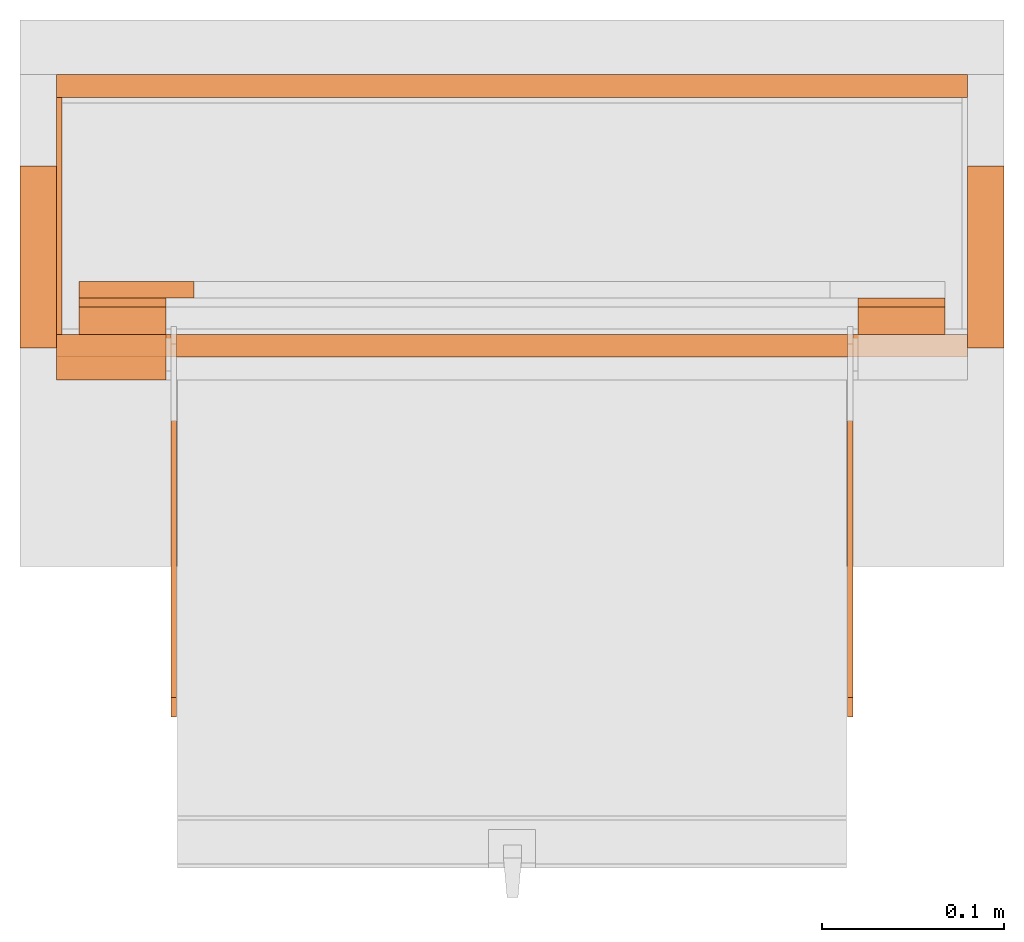
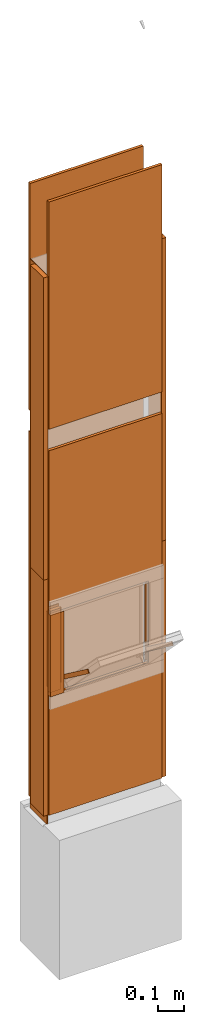
# One storey, part 1 of 3: 18 proxies, 1 opening.
"""IFC2X3 building model written with IfcOpenShell, lengths in metres."""

from ifc_helpers import new_model, entity, si_unit, converted_unit, derived_unit, money_unit, direction, frame, origin_with_axes, origin_2d_with_axis, place, context, subcontext, project, spatial, polyline, rectangle, outline, extrude, faceted_brep, source, transform, mapped, material, type_object, element, save


model = new_model("IFC2X3")

# Units and contexts
model_context = context("Model", 3, precision=1e-05, world=origin_with_axes(), true_north=direction((0.0, 1.0)))
plan_context = context("Plan", 3, precision=1e-05, world=origin_with_axes(), true_north=direction((0.0, 1.0)))
body_context = subcontext(model_context, "Body", "Model", "MODEL_VIEW")
ifc_project = project(units=[si_unit("LENGTHUNIT", "METRE"), si_unit("AREAUNIT", "SQUARE_METRE"), si_unit("VOLUMEUNIT", "CUBIC_METRE"), converted_unit("PLANEANGLEUNIT", "DEGREE", entity("IfcPlaneAngleMeasure", 0.0174532925199), si_unit("PLANEANGLEUNIT", "RADIAN"), dimensions=[0, 0, 0, 0, 0, 0, 0]), si_unit("SOLIDANGLEUNIT", "STERADIAN"), money_unit("CHF"), converted_unit("TIMEUNIT", "Year", entity("IfcTimeMeasure", 31556926.0), si_unit("TIMEUNIT", "SECOND"), dimensions=[0, 0, 1, 0, 0, 0, 0]), si_unit("MASSUNIT", "GRAM", prefix="KILO"), si_unit("THERMODYNAMICTEMPERATUREUNIT", "DEGREE_CELSIUS"), si_unit("LUMINOUSINTENSITYUNIT", "LUMEN"), si_unit("ENERGYUNIT", "JOULE", prefix="MEGA"), derived_unit("THERMALCONDUCTANCEUNIT", [(si_unit("POWERUNIT", "WATT"), 1), (si_unit("LENGTHUNIT", "METRE"), -1), (si_unit("THERMODYNAMICTEMPERATUREUNIT", "KELVIN"), -1)]), derived_unit("SPECIFICHEATCAPACITYUNIT", [(si_unit("ENERGYUNIT", "JOULE"), 1), (si_unit("MASSUNIT", "GRAM", prefix="KILO"), -1), (si_unit("THERMODYNAMICTEMPERATUREUNIT", "KELVIN"), -1)]), derived_unit("MASSDENSITYUNIT", [(si_unit("MASSUNIT", "GRAM", prefix="KILO"), 1), (si_unit("VOLUMEUNIT", "CUBIC_METRE"), -1)])], contexts=[model_context, plan_context])

# Site, building, storey
site_placement = place(None, origin_with_axes())
site = spatial("IfcSite", under=ifc_project, at=site_placement, CompositionType="ELEMENT")
building_placement = place(site_placement, origin_with_axes())
building = spatial("IfcBuilding", under=site, at=building_placement, CompositionType="ELEMENT")
storey_placement = place(building_placement, origin_with_axes())
storey = spatial("IfcBuildingStorey", under=building, at=storey_placement, Name="EG00", CompositionType="ELEMENT", Elevation=0.0)

# Proxies
ifc_material_1 = material(Name="Metall, Stahl")
building_element_proxy_type_1 = type_object("IfcBuildingElementProxyType", Name="Metall, Stahl 3", PredefinedType="NOTDEFINED")
proxy_1_placement = place(storey_placement, frame((9.11522436818, -3.75878861887, 0.0), z_axis=(0.0, 0.0, 1.0), x_axis=(0.0, -1.0, 0.0)))
element("IfcBuildingElementProxy", 1, at=proxy_1_placement, inside=storey, type_object=building_element_proxy_type_1, material=ifc_material_1, Name="Wand-005", context=body_context, shape_type="SweptSolid", body=[
    extrude(outline(polyline([(0.0, 0.0), (0.13, 0.0), (0.13, 0.003), (0.0, 0.003), (0.0, 0.0)])), origin_with_axes(), (0.0, 0.0, 1.0), 1.15),
])
proxy_2_placement = place(storey_placement, frame((9.11522436818, -3.75878861887, 1.15), z_axis=(0.0, 0.0, 1.0), x_axis=(0.0, -1.0, 0.0)))
element("IfcBuildingElementProxy", 2, at=proxy_2_placement, inside=storey, type_object=building_element_proxy_type_1, material=ifc_material_1, Name="Wand-005", context=body_context, shape_type="SweptSolid", body=[
    extrude(outline(polyline([(0.0, 0.0), (0.13, 0.0), (0.13, 0.003), (0.0, 0.003), (0.0, 0.0)])), origin_with_axes(), (0.0, 0.0, 1.0), 1.41),
])
ifc_material_2 = material(Name="Holz")
building_element_proxy_type_2 = type_object("IfcBuildingElementProxyType", Name="Holz 15", PredefinedType="NOTDEFINED")
for number, where, z_axis, x_axis, name in (
    (3, (9.55522436818, -3.88878861887, 0.61), (0.0, 0.0, 1.0), (1.0, 0.0, 0.0), "Wand-004"),
    (4, (9.12772436818, -3.88878861887, 0.61), (0.0, 0.0, 1.0), (1.0, 0.0, 0.0), "Wand-004"),
):
    element("IfcBuildingElementProxy", number, at=place(storey_placement, frame(where, z_axis=z_axis, x_axis=x_axis)), inside=storey, type_object=building_element_proxy_type_2, material=ifc_material_2, Name=name, context=body_context, shape_type="SweptSolid", body=[
        extrude(outline(polyline([(0.0, 0.0), (0.0475, 0.0), (0.0475, 0.015), (0.0, 0.015), (0.0, 0.0)])), origin_with_axes(), (0.0, 0.0, 1.0), 0.38),
    ])
building_element_proxy_type_3 = type_object("IfcBuildingElementProxyType", Name="Holz 25", PredefinedType="NOTDEFINED")
proxy_3_placement = place(storey_placement, frame((9.11522436818, -3.91378861887, 0.61), z_axis=(0.0, 0.0, 1.0), x_axis=(1.0, 0.0, 0.0)))
element("IfcBuildingElementProxy", 5, at=proxy_3_placement, inside=storey, type_object=building_element_proxy_type_3, material=ifc_material_2, Name="Wand-004", context=body_context, shape_type="SweptSolid", body=[
    extrude(outline(polyline([(0.0, 0.0), (0.06, 0.0), (0.06, 0.025), (0.0, 0.025), (0.0, 0.0)])), origin_with_axes(), (0.0, 0.0, 1.0), 0.38),
])
building_element_proxy_type_4 = type_object("IfcBuildingElementProxyType", Name="Holz 5", PredefinedType="NOTDEFINED")
for number, where, z_axis, x_axis, name in (
    (6, (9.12772436818, -3.87378861887, 0.6), (0.0, 0.0, 1.0), (1.0, 0.0, 0.0), "Wand-004"),
    (7, (9.55522436818, -3.87378861887, 0.6), (0.0, 0.0, 1.0), (1.0, 0.0, 0.0), "Wand-004"),
):
    element("IfcBuildingElementProxy", number, at=place(storey_placement, frame(where, z_axis=z_axis, x_axis=x_axis)), inside=storey, type_object=building_element_proxy_type_4, material=ifc_material_2, Name=name, context=body_context, shape_type="SweptSolid", body=[
        extrude(outline(polyline([(0.0, 0.0), (0.0475, 0.0), (0.0475, 0.005), (0.0, 0.005), (0.0, 0.0)])), origin_with_axes(), (0.0, 0.0, 1.0), 0.4),
    ])
ifc_material_3 = material(Name="Metall, Aluminium")
building_element_proxy_type_5 = type_object("IfcBuildingElementProxyType", Name="Metall, Aluminium", PredefinedType="NOTDEFINED")
shared_shape = source(origin_with_axes(), body_context, "Body", "Brep", [
    faceted_brep([(16.1152851057, -3.58730556817, 0.89), (16.1152851057, -3.59030556817, 0.89), (16.1152851057, -3.59030556817, 1.14), (16.1152851057, -3.58730556817, 1.14), (16.1332851057, -3.59030556817, 0.89), (16.1332851057, -3.58730556817, 0.89), (16.1332851057, -3.59030556817, 1.14), (16.1332851057, -3.58730556817, 1.14)], [[[0, 1, 2, 3]], [[4, 1, 0, 5]], [[1, 4, 6, 2]], [[2, 6, 7, 3]], [[0, 3, 7, 5]], [[4, 5, 7, 6]]]),
])
for number, where, z_axis, x_axis, name in (
    (8, (13.1395299364, 6.43632697465, 13.081222354), (0.0, -0.80277012101, 0.596288632135), (0.0, -0.596288632135, -0.80277012101), "Wand-004"),
    (9, (12.7685299364, 6.43632697465, 13.081222354), (0.0, -0.80277012101, 0.596288632135), (0.0, -0.596288632135, -0.80277012101), "Wand-004"),
):
    element("IfcBuildingElementProxy", number, at=place(storey_placement, frame(where, z_axis=z_axis, x_axis=x_axis)), inside=storey, type_object=building_element_proxy_type_5, material=ifc_material_3, Name=name, context=body_context, shape_type="MappedRepresentation", body=[
        mapped(shared_shape, transform((0.0, 0.0, 0.0))),
    ])
building_element_proxy_type_6 = type_object("IfcBuildingElementProxyType", Name="Holz 9", PredefinedType="NOTDEFINED")
proxy_4_placement = place(storey_placement, frame((9.12772436818, -3.86878861887, 0.625), z_axis=(0.0, 0.0, 1.0), x_axis=(1.0, 0.0, 0.0)))
element("IfcBuildingElementProxy", 10, at=proxy_4_placement, inside=storey, type_object=building_element_proxy_type_6, material=ifc_material_2, Name="Wand-004", context=body_context, shape_type="SweptSolid", body=[
    extrude(outline(polyline([(0.0, 0.0), (0.063, 0.0), (0.063, 0.009), (0.0, 0.009), (0.0, 0.0)])), origin_with_axes(), (0.0, 0.0, 1.0), 0.35),
])

# Proxy, opening
ifc_material_4 = material(Name="Gipsplatte horizontal")
building_element_proxy_type_7 = type_object("IfcBuildingElementProxyType", Name="Gipsplatte horizontal 13", PredefinedType="NOTDEFINED")
proxy_5_placement = place(storey_placement, frame((9.11522436818, -3.90128861887, 0.05), z_axis=(0.0, 0.0, 1.0), x_axis=(1.0, 0.0, 0.0)))
proxy_5 = element("IfcBuildingElementProxy", 11, at=proxy_5_placement, inside=storey, type_object=building_element_proxy_type_7, material=ifc_material_4, Name="Wand-004", context=body_context, shape_type="SweptSolid", body=[
    extrude(outline(polyline([(0.0, 0.0), (0.5, 0.0), (0.5, 0.0125), (0.0, 0.0125), (0.0, 0.0)])), origin_with_axes(), (0.0, 0.0, 1.0), 1.7),
])
opening_placement = place(proxy_5_placement, frame((-9.11522436818, 3.90128861887, -0.05), z_axis=(0.0, 0.0, 1.0), x_axis=(1.0, 0.0, 0.0)))
element("IfcOpeningElement", 12, at=opening_placement, cuts=proxy_5, Name="028", context=body_context, shape_type="SweptSolid", body=[
    extrude(rectangle(XDim=0.38, YDim=0.38, at=origin_2d_with_axis()), frame((9.36522436818, -3.91378861887, 0.8), z_axis=(0.0, -1.0, 0.0), x_axis=(1.0, 0.0, 0.0)), (0.0, 0.0, -1.0), 0.0375),
])

# Proxies
proxy_6_placement = place(storey_placement, frame((9.11522436818, -3.74628861887, 0.05), z_axis=(0.0, 0.0, 1.0), x_axis=(1.0, 0.0, 0.0)))
element("IfcBuildingElementProxy", 13, at=proxy_6_placement, inside=storey, type_object=building_element_proxy_type_7, material=ifc_material_4, Name="Wand-004", context=body_context, shape_type="SweptSolid", body=[
    extrude(outline(polyline([(0.0, -0.0125), (0.5, -0.0125), (0.5, 0.0), (0.0, 0.0), (0.0, -0.0125)])), origin_with_axes(), (0.0, 0.0, 1.0), 1.7),
])
proxy_7_placement = place(storey_placement, frame((9.11522436818, -3.90128861887, 1.85), z_axis=(0.0, 0.0, 1.0), x_axis=(1.0, 0.0, 0.0)))
element("IfcBuildingElementProxy", 14, at=proxy_7_placement, inside=storey, type_object=building_element_proxy_type_7, material=ifc_material_4, Name="Wand-004", context=body_context, shape_type="SweptSolid", body=[
    extrude(outline(polyline([(0.0, 0.0), (0.5, 0.0), (0.5, 0.0125), (0.0, 0.0125), (0.0, 0.0)])), origin_with_axes(), (0.0, 0.0, 1.0), 1.06),
])
proxy_8_placement = place(storey_placement, frame((9.11522436818, -3.74628861887, 1.85), z_axis=(0.0, 0.0, 1.0), x_axis=(1.0, 0.0, 0.0)))
element("IfcBuildingElementProxy", 15, at=proxy_8_placement, inside=storey, type_object=building_element_proxy_type_7, material=ifc_material_4, Name="Wand-004", context=body_context, shape_type="SweptSolid", body=[
    extrude(outline(polyline([(0.0, -0.0125), (0.5, -0.0125), (0.5, 0.0), (0.0, 0.0), (0.0, -0.0125)])), origin_with_axes(), (0.0, 0.0, 1.0), 1.06),
])
building_element_proxy_type_8 = type_object("IfcBuildingElementProxyType", Name="Holz 20", PredefinedType="NOTDEFINED")
proxy_9_placement = place(storey_placement, frame((9.09522436818, -3.79628861887, 0.05), z_axis=(0.0, 0.0, 1.0), x_axis=(0.0, -1.0, 0.0)))
element("IfcBuildingElementProxy", 16, at=proxy_9_placement, inside=storey, type_object=building_element_proxy_type_8, material=ifc_material_2, Name="Wand-004", context=body_context, shape_type="SweptSolid", body=[
    extrude(outline(polyline([(0.0, 0.0), (0.1, 0.0), (0.1, 0.02), (0.0, 0.02), (0.0, 0.0)])), origin_with_axes(), (0.0, 0.0, 1.0), 1.1),
])
proxy_10_placement = place(storey_placement, frame((9.63522436818, -3.79628861887, 0.05), z_axis=(0.0, 0.0, 1.0), x_axis=(0.0, -1.0, 0.0)))
element("IfcBuildingElementProxy", 17, at=proxy_10_placement, inside=storey, type_object=building_element_proxy_type_8, material=ifc_material_2, Name="Wand-003", context=body_context, shape_type="SweptSolid", body=[
    extrude(outline(polyline([(0.0, -0.02), (0.1, -0.02), (0.1, 0.0), (0.0, 0.0), (0.0, -0.02)])), origin_with_axes(), (0.0, 0.0, 1.0), 1.1),
])
proxy_11_placement = place(storey_placement, frame((9.09522436818, -3.79628861887, 1.15), z_axis=(0.0, 0.0, 1.0), x_axis=(0.0, -1.0, 0.0)))
element("IfcBuildingElementProxy", 18, at=proxy_11_placement, inside=storey, type_object=building_element_proxy_type_8, material=ifc_material_2, Name="Wand-004", context=body_context, shape_type="SweptSolid", body=[
    extrude(outline(polyline([(0.0, 0.0), (0.1, 0.0), (0.1, 0.02), (0.0, 0.02), (0.0, 0.0)])), origin_with_axes(), (0.0, 0.0, 1.0), 1.41),
])
proxy_12_placement = place(storey_placement, frame((9.63522436818, -3.79628861887, 1.15), z_axis=(0.0, 0.0, 1.0), x_axis=(0.0, -1.0, 0.0)))
element("IfcBuildingElementProxy", 19, at=proxy_12_placement, inside=storey, type_object=building_element_proxy_type_8, material=ifc_material_2, Name="Wand-003", context=body_context, shape_type="SweptSolid", body=[
    extrude(outline(polyline([(0.0, -0.02), (0.1, -0.02), (0.1, 0.0), (0.0, 0.0), (0.0, -0.02)])), origin_with_axes(), (0.0, 0.0, 1.0), 1.41),
])

save(model, "model.ifc")
